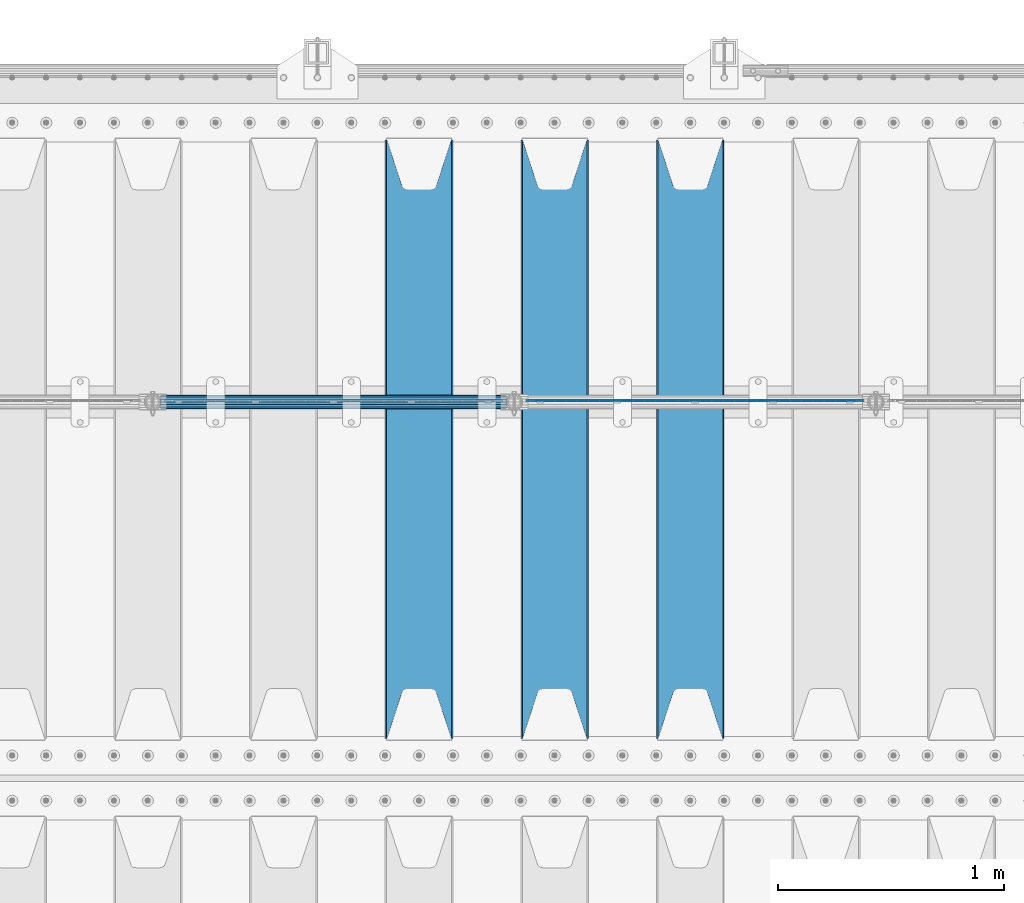
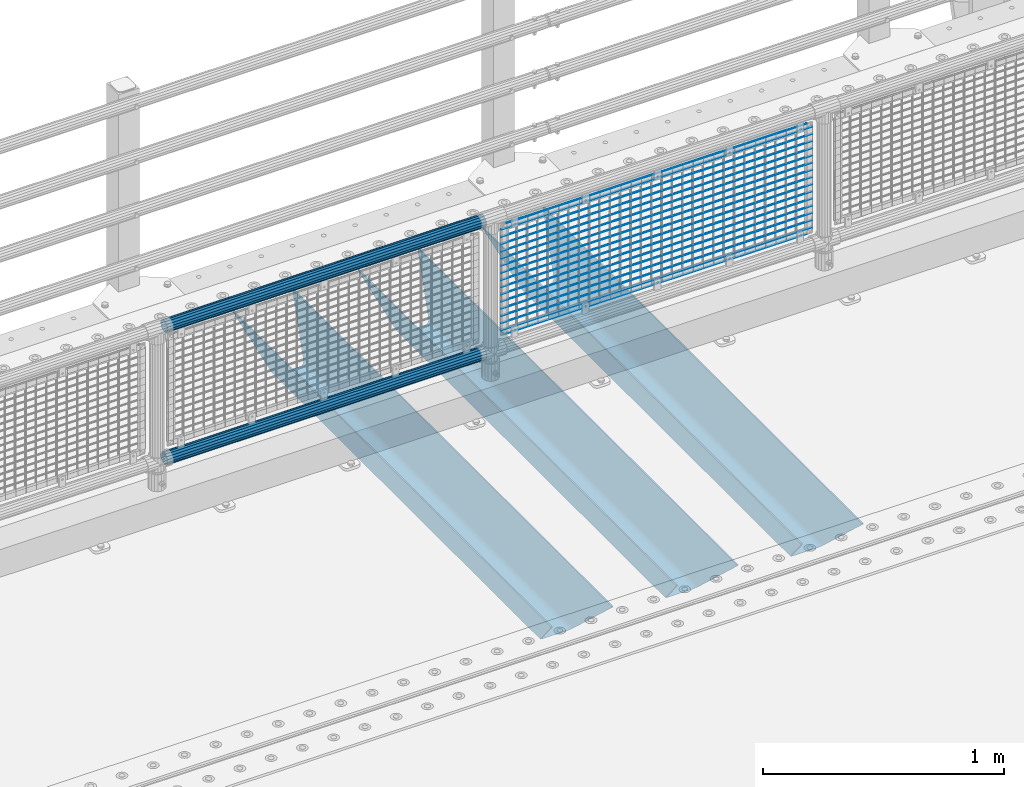
# One storey, part 103 of 208: 22 beams.
"""IFC2X3 building model written with IfcOpenShell, lengths in millimetres."""

from ifc_helpers import new_model, si_unit, frame, origin_with_axes, place, context, subcontext, project, spatial, faceted_brep, material, type_object, element, save


model = new_model("IFC2X3")

# Units and contexts
model_context = context("Model", 3, precision=1e-05, world=origin_with_axes())
body_context = subcontext(model_context, "Body", "Model", "MODEL_VIEW")
ifc_project = project(units=[si_unit("LENGTHUNIT", "METRE", prefix="MILLI"), si_unit("AREAUNIT", "SQUARE_METRE"), si_unit("VOLUMEUNIT", "CUBIC_METRE"), si_unit("MASSUNIT", "GRAM", prefix="KILO"), si_unit("TIMEUNIT", "SECOND"), si_unit("PLANEANGLEUNIT", "RADIAN"), si_unit("SOLIDANGLEUNIT", "STERADIAN"), si_unit("THERMODYNAMICTEMPERATUREUNIT", "DEGREE_CELSIUS"), si_unit("LUMINOUSINTENSITYUNIT", "LUMEN")], contexts=[model_context])

# Site, building, storey
site_placement = place(None, origin_with_axes())
site = spatial("IfcSite", under=ifc_project, at=site_placement, CompositionType="ELEMENT")
building_placement = place(site_placement, origin_with_axes())
building = spatial("IfcBuilding", under=site, at=building_placement, Name="Standard", CompositionType="ELEMENT")
storey_placement = place(building_placement, origin_with_axes())
storey = spatial("IfcBuildingStorey", under=building, at=storey_placement, Name="Undefined", CompositionType="ELEMENT", Elevation=0.0)

# Beams
ifc_material_1 = material(Name="STEEL/S355N")
beam_type_1 = type_object("IfcBeamType", PredefinedType="NOTDEFINED")
beam_1_placement = place(storey_placement, frame((-33050.0, 3175.0, -115.0), z_axis=(0.0, 0.0, 1.0), x_axis=(0.0, 1.0, 0.0)))
element("IfcBeam", 1, at=beam_1_placement, inside=storey, type_object=beam_type_1, material=ifc_material_1, context=body_context, shape_type="Brep", body=[
    faceted_brep([(0.0, 150.0, 115.0), (0.0, 143.689999999999, 115.0), (2650.00000000297, 143.689999999999, 115.0), (2650.00000000297, 150.0, 115.0), (2650.00000000297, 142.059565218402, 110.0000000031), (2650.00000000297, 148.369565218403, 110.0000000031), (2441.90079219208, -80.1103600731112, -98.0992078077845), (2437.7588105432, -77.5672621345584, -102.241189456673), (2434.06523489746, -74.4080125315522, -105.934765102404), (2430.91086095089, -70.710272125576, -109.089139048974), (2428.37322971128, -66.5649389910068, -111.626770288588), (2426.51472138055, -62.0739139532889, -113.485278619323), (2425.38102192091, -57.3475956567672, -114.618978078955), (2424.99999999987, -52.5021667386536, -115.0), (2424.99999999987, 52.5021667386536, -115.0), (2425.38102192091, 57.3475956567672, -114.618978078955), (2426.51472138055, 62.0739139532889, -113.485278619323), (2428.37322971128, 66.5649389910068, -111.626770288588), (2430.91086095089, 70.710272125576, -109.089139048974), (2434.06523489746, 74.4080125315522, -105.934765102404), (2437.7588105432, 77.5672621345584, -102.241189456673), (2441.90079219208, 80.1103600731112, -98.0992078077846), (2446.38936140511, 81.9747917625791, -93.6106385947584), (2448.24948500409, 76.2713538057251, -91.7505149957729), (2444.62967112262, 74.76777986261, -95.3703288772456), (2441.28936334126, 72.7168944282894, -98.710636658607), (2438.31067330438, 70.1691124903846, -101.689326695487), (2435.76682334747, 67.1870637758839, -104.233176652398), (2433.72034654133, 63.8440531834895, -106.279653458539), (2432.22154950041, 60.222258798236, -107.778450499454), (2431.30727574265, 56.4107117849089, -108.692724257221), (2430.99999999987, 52.5031078186876, -109.0), (2430.99999999987, -52.5031078186876, -109.0), (2431.30727574265, -56.4107117849089, -108.692724257221), (2432.22154950041, -60.222258798236, -107.778450499454), (2433.72034654133, -63.8440531834895, -106.279653458539), (2435.76682334747, -67.1870637758839, -104.233176652398), (2438.31067330438, -70.1691124903846, -101.689326695487), (2441.28936334126, -72.7168944282894, -98.7106366586071), (2444.62967112262, -74.76777986261, -95.3703288772457), (2448.24948500409, -76.2713538057251, -91.7505149957729), (2650.00000000297, -142.059565218402, 110.0000000031), (2650.00000000297, -148.369565218403, 110.0000000031), (2446.38936140511, -81.9747917625791, -93.6106385947584), (2650.00000000297, -143.689999999999, 115.0), (2650.00000000297, -150.0, 115.0), (0.0, -143.689999999999, 115.0), (0.0, -150.0, 115.0), (0.0, -148.369565218261, 110.000000002663), (203.610638597421, -81.9747917625791, -93.6106385947584), (208.099207810448, -80.1103600731112, -98.0992078077845), (212.241189459336, -77.5672621345584, -102.241189456673), (215.934765105067, -74.4080125315522, -105.934765102404), (219.089139051637, -70.710272125576, -109.089139048974), (221.626770291251, -66.5649389910068, -111.626770288588), (223.485278621986, -62.0739139532889, -113.485278619323), (224.618978081618, -57.3475956567672, -114.618978078955), (225.000000002663, -52.5021667386536, -115.0), (225.000000002663, 52.5021667386536, -115.0), (224.618978081618, 57.3475956567672, -114.618978078955), (223.485278621986, 62.0739139532889, -113.485278619323), (221.626770291251, 66.5649389910068, -111.626770288588), (219.089139051637, 70.710272125576, -109.089139048974), (215.934765105067, 74.4080125315522, -105.934765102404), (212.241189459336, 77.5672621345584, -102.241189456673), (208.099207810448, 80.1103600731112, -98.0992078077846), (203.610638597421, 81.9747917625791, -93.6106385947584), (0.0, 148.369565218261, 110.000000002663), (0.0, 142.05956521826, 110.000000002663), (201.750514998436, 76.2713538057251, -91.7505149957729), (205.370328879908, 74.76777986261, -95.3703288772456), (208.71063666127, 72.7168944282894, -98.710636658607), (211.68932669815, 70.1691124903846, -101.689326695487), (214.233176655061, 67.1870637758839, -104.233176652398), (216.279653461202, 63.8440531834895, -106.279653458539), (217.778450502116, 60.222258798236, -107.778450499454), (218.692724259884, 56.4107117849089, -108.692724257221), (219.000000002663, 52.5031078186876, -109.0), (219.000000002663, -52.5031078186876, -109.0), (218.692724259884, -56.4107117849089, -108.692724257221), (217.778450502116, -60.222258798236, -107.778450499454), (216.279653461202, -63.8440531834895, -106.279653458539), (214.233176655061, -67.1870637758839, -104.233176652398), (211.68932669815, -70.1691124903846, -101.689326695487), (208.71063666127, -72.7168944282894, -98.7106366586071), (205.370328879908, -74.76777986261, -95.3703288772457), (201.750514998436, -76.2713538057251, -91.7505149957729), (0.0, -142.05956521826, 110.000000002663)], [[[0, 1, 2, 3]], [[3, 2, 4, 5]], [[6, 7, 8, 9, 10, 11, 12, 13, 14, 15, 16, 17, 18, 19, 20, 21, 22, 5, 4, 23, 24, 25, 26, 27, 28, 29, 30, 31, 32, 33, 34, 35, 36, 37, 38, 39, 40, 41, 42, 43]], [[44, 45, 42, 41]], [[46, 47, 45, 44]], [[43, 42, 45, 47, 48, 49]], [[6, 43, 49, 50]], [[7, 6, 50, 51]], [[8, 7, 51, 52]], [[9, 8, 52, 53]], [[10, 9, 53, 54]], [[11, 10, 54, 55]], [[12, 11, 55, 56]], [[13, 12, 56, 57]], [[14, 13, 57, 58]], [[15, 14, 58, 59]], [[16, 15, 59, 60]], [[17, 16, 60, 61]], [[18, 17, 61, 62]], [[19, 18, 62, 63]], [[20, 19, 63, 64]], [[21, 20, 64, 65]], [[22, 21, 65, 66]], [[0, 3, 5, 22, 66, 67]], [[1, 0, 67, 68]], [[23, 4, 2, 1, 68, 69]], [[24, 23, 69, 70]], [[25, 24, 70, 71]], [[26, 25, 71, 72]], [[27, 26, 72, 73]], [[28, 27, 73, 74]], [[29, 28, 74, 75]], [[30, 29, 75, 76]], [[31, 30, 76, 77]], [[32, 31, 77, 78]], [[33, 32, 78, 79]], [[34, 33, 79, 80]], [[35, 34, 80, 81]], [[36, 35, 81, 82]], [[37, 36, 82, 83]], [[38, 37, 83, 84]], [[39, 38, 84, 85]], [[40, 39, 85, 86]], [[46, 44, 41, 40, 86, 87]], [[47, 46, 87, 48]], [[86, 85, 84, 83, 82, 81, 80, 79, 78, 77, 76, 75, 74, 73, 72, 71, 70, 69, 68, 67, 66, 65, 64, 63, 62, 61, 60, 59, 58, 57, 56, 55, 54, 53, 52, 51, 50, 49, 48, 87]]]),
])
beam_2_placement = place(storey_placement, frame((-33650.0, 3175.0, -115.0), z_axis=(0.0, 0.0, 1.0), x_axis=(0.0, 1.0, 0.0)))
element("IfcBeam", 2, at=beam_2_placement, inside=storey, type_object=beam_type_1, material=ifc_material_1, context=body_context, shape_type="Brep", body=[
    faceted_brep([(0.0, 150.0, 115.0), (0.0, 143.689999999999, 115.0), (2650.00000000297, 143.689999999999, 115.0), (2650.00000000297, 150.0, 115.0), (2650.00000000297, 142.059565218402, 110.0000000031), (2650.00000000297, 148.369565218403, 110.0000000031), (2441.90079219208, -80.1103600731112, -98.0992078077845), (2437.7588105432, -77.5672621345584, -102.241189456673), (2434.06523489746, -74.4080125315522, -105.934765102404), (2430.91086095089, -70.710272125576, -109.089139048974), (2428.37322971128, -66.5649389910068, -111.626770288588), (2426.51472138055, -62.0739139532889, -113.485278619323), (2425.38102192091, -57.3475956567672, -114.618978078955), (2424.99999999987, -52.5021667386536, -115.0), (2424.99999999987, 52.5021667386536, -115.0), (2425.38102192091, 57.3475956567672, -114.618978078955), (2426.51472138055, 62.0739139532889, -113.485278619323), (2428.37322971128, 66.5649389910068, -111.626770288588), (2430.91086095089, 70.710272125576, -109.089139048974), (2434.06523489746, 74.4080125315522, -105.934765102404), (2437.7588105432, 77.5672621345584, -102.241189456673), (2441.90079219208, 80.1103600731112, -98.0992078077846), (2446.38936140511, 81.9747917625791, -93.6106385947584), (2448.24948500409, 76.2713538057251, -91.7505149957729), (2444.62967112262, 74.76777986261, -95.3703288772456), (2441.28936334126, 72.7168944282894, -98.710636658607), (2438.31067330438, 70.1691124903846, -101.689326695487), (2435.76682334747, 67.1870637758839, -104.233176652398), (2433.72034654133, 63.8440531834895, -106.279653458539), (2432.22154950041, 60.222258798236, -107.778450499454), (2431.30727574265, 56.4107117849089, -108.692724257221), (2430.99999999987, 52.5031078186876, -109.0), (2430.99999999987, -52.5031078186876, -109.0), (2431.30727574265, -56.4107117849089, -108.692724257221), (2432.22154950041, -60.222258798236, -107.778450499454), (2433.72034654133, -63.8440531834895, -106.279653458539), (2435.76682334747, -67.1870637758839, -104.233176652398), (2438.31067330438, -70.1691124903846, -101.689326695487), (2441.28936334126, -72.7168944282894, -98.7106366586071), (2444.62967112262, -74.76777986261, -95.3703288772457), (2448.24948500409, -76.2713538057251, -91.7505149957729), (2650.00000000297, -142.059565218402, 110.0000000031), (2650.00000000297, -148.369565218403, 110.0000000031), (2446.38936140511, -81.9747917625791, -93.6106385947584), (2650.00000000297, -143.689999999999, 115.0), (2650.00000000297, -150.0, 115.0), (0.0, -143.689999999999, 115.0), (0.0, -150.0, 115.0), (0.0, -148.369565218261, 110.000000002663), (203.610638597421, -81.9747917625791, -93.6106385947584), (208.099207810448, -80.1103600731112, -98.0992078077845), (212.241189459336, -77.5672621345584, -102.241189456673), (215.934765105067, -74.4080125315522, -105.934765102404), (219.089139051637, -70.710272125576, -109.089139048974), (221.626770291251, -66.5649389910068, -111.626770288588), (223.485278621986, -62.0739139532889, -113.485278619323), (224.618978081618, -57.3475956567672, -114.618978078955), (225.000000002663, -52.5021667386536, -115.0), (225.000000002663, 52.5021667386536, -115.0), (224.618978081618, 57.3475956567672, -114.618978078955), (223.485278621986, 62.0739139532889, -113.485278619323), (221.626770291251, 66.5649389910068, -111.626770288588), (219.089139051637, 70.710272125576, -109.089139048974), (215.934765105067, 74.4080125315522, -105.934765102404), (212.241189459336, 77.5672621345584, -102.241189456673), (208.099207810448, 80.1103600731112, -98.0992078077846), (203.610638597421, 81.9747917625791, -93.6106385947584), (0.0, 148.369565218261, 110.000000002663), (0.0, 142.05956521826, 110.000000002663), (201.750514998436, 76.2713538057251, -91.7505149957729), (205.370328879908, 74.76777986261, -95.3703288772456), (208.71063666127, 72.7168944282894, -98.710636658607), (211.68932669815, 70.1691124903846, -101.689326695487), (214.233176655061, 67.1870637758839, -104.233176652398), (216.279653461202, 63.8440531834895, -106.279653458539), (217.778450502116, 60.222258798236, -107.778450499454), (218.692724259884, 56.4107117849089, -108.692724257221), (219.000000002663, 52.5031078186876, -109.0), (219.000000002663, -52.5031078186876, -109.0), (218.692724259884, -56.4107117849089, -108.692724257221), (217.778450502116, -60.222258798236, -107.778450499454), (216.279653461202, -63.8440531834895, -106.279653458539), (214.233176655061, -67.1870637758839, -104.233176652398), (211.68932669815, -70.1691124903846, -101.689326695487), (208.71063666127, -72.7168944282894, -98.7106366586071), (205.370328879908, -74.76777986261, -95.3703288772457), (201.750514998436, -76.2713538057251, -91.7505149957729), (0.0, -142.05956521826, 110.000000002663)], [[[0, 1, 2, 3]], [[3, 2, 4, 5]], [[6, 7, 8, 9, 10, 11, 12, 13, 14, 15, 16, 17, 18, 19, 20, 21, 22, 5, 4, 23, 24, 25, 26, 27, 28, 29, 30, 31, 32, 33, 34, 35, 36, 37, 38, 39, 40, 41, 42, 43]], [[44, 45, 42, 41]], [[46, 47, 45, 44]], [[43, 42, 45, 47, 48, 49]], [[6, 43, 49, 50]], [[7, 6, 50, 51]], [[8, 7, 51, 52]], [[9, 8, 52, 53]], [[10, 9, 53, 54]], [[11, 10, 54, 55]], [[12, 11, 55, 56]], [[13, 12, 56, 57]], [[14, 13, 57, 58]], [[15, 14, 58, 59]], [[16, 15, 59, 60]], [[17, 16, 60, 61]], [[18, 17, 61, 62]], [[19, 18, 62, 63]], [[20, 19, 63, 64]], [[21, 20, 64, 65]], [[22, 21, 65, 66]], [[0, 3, 5, 22, 66, 67]], [[1, 0, 67, 68]], [[23, 4, 2, 1, 68, 69]], [[24, 23, 69, 70]], [[25, 24, 70, 71]], [[26, 25, 71, 72]], [[27, 26, 72, 73]], [[28, 27, 73, 74]], [[29, 28, 74, 75]], [[30, 29, 75, 76]], [[31, 30, 76, 77]], [[32, 31, 77, 78]], [[33, 32, 78, 79]], [[34, 33, 79, 80]], [[35, 34, 80, 81]], [[36, 35, 81, 82]], [[37, 36, 82, 83]], [[38, 37, 83, 84]], [[39, 38, 84, 85]], [[40, 39, 85, 86]], [[46, 44, 41, 40, 86, 87]], [[47, 46, 87, 48]], [[86, 85, 84, 83, 82, 81, 80, 79, 78, 77, 76, 75, 74, 73, 72, 71, 70, 69, 68, 67, 66, 65, 64, 63, 62, 61, 60, 59, 58, 57, 56, 55, 54, 53, 52, 51, 50, 49, 48, 87]]]),
])
beam_3_placement = place(storey_placement, frame((-34250.0, 3175.0, -115.0), z_axis=(0.0, 0.0, 1.0), x_axis=(0.0, 1.0, 0.0)))
element("IfcBeam", 3, at=beam_3_placement, inside=storey, type_object=beam_type_1, material=ifc_material_1, context=body_context, shape_type="Brep", body=[
    faceted_brep([(0.0, 150.0, 115.0), (0.0, 143.689999999999, 115.0), (2650.00000000297, 143.689999999999, 115.0), (2650.00000000297, 150.0, 115.0), (2650.00000000297, 142.059565218402, 110.0000000031), (2650.00000000297, 148.369565218403, 110.0000000031), (2441.90079219208, -80.1103600731112, -98.0992078077845), (2437.7588105432, -77.5672621345584, -102.241189456673), (2434.06523489746, -74.4080125315522, -105.934765102404), (2430.91086095089, -70.710272125576, -109.089139048974), (2428.37322971128, -66.5649389910068, -111.626770288588), (2426.51472138055, -62.0739139532889, -113.485278619323), (2425.38102192091, -57.3475956567672, -114.618978078955), (2424.99999999987, -52.5021667386536, -115.0), (2424.99999999987, 52.5021667386536, -115.0), (2425.38102192091, 57.3475956567672, -114.618978078955), (2426.51472138055, 62.0739139532889, -113.485278619323), (2428.37322971128, 66.5649389910068, -111.626770288588), (2430.91086095089, 70.710272125576, -109.089139048974), (2434.06523489746, 74.4080125315522, -105.934765102404), (2437.7588105432, 77.5672621345584, -102.241189456673), (2441.90079219208, 80.1103600731112, -98.0992078077846), (2446.38936140511, 81.9747917625791, -93.6106385947584), (2448.24948500409, 76.2713538057251, -91.7505149957729), (2444.62967112262, 74.76777986261, -95.3703288772456), (2441.28936334126, 72.7168944282894, -98.710636658607), (2438.31067330438, 70.1691124903846, -101.689326695487), (2435.76682334747, 67.1870637758839, -104.233176652398), (2433.72034654133, 63.8440531834895, -106.279653458539), (2432.22154950041, 60.222258798236, -107.778450499454), (2431.30727574265, 56.4107117849089, -108.692724257221), (2430.99999999987, 52.5031078186876, -109.0), (2430.99999999987, -52.5031078186876, -109.0), (2431.30727574265, -56.4107117849089, -108.692724257221), (2432.22154950041, -60.222258798236, -107.778450499454), (2433.72034654133, -63.8440531834895, -106.279653458539), (2435.76682334747, -67.1870637758839, -104.233176652398), (2438.31067330438, -70.1691124903846, -101.689326695487), (2441.28936334126, -72.7168944282894, -98.7106366586071), (2444.62967112262, -74.76777986261, -95.3703288772457), (2448.24948500409, -76.2713538057251, -91.7505149957729), (2650.00000000297, -142.059565218402, 110.0000000031), (2650.00000000297, -148.369565218403, 110.0000000031), (2446.38936140511, -81.9747917625791, -93.6106385947584), (2650.00000000297, -143.689999999999, 115.0), (2650.00000000297, -150.0, 115.0), (0.0, -143.689999999999, 115.0), (0.0, -150.0, 115.0), (0.0, -148.369565218261, 110.000000002663), (203.610638597421, -81.9747917625791, -93.6106385947584), (208.099207810448, -80.1103600731112, -98.0992078077845), (212.241189459336, -77.5672621345584, -102.241189456673), (215.934765105067, -74.4080125315522, -105.934765102404), (219.089139051637, -70.710272125576, -109.089139048974), (221.626770291251, -66.5649389910068, -111.626770288588), (223.485278621986, -62.0739139532889, -113.485278619323), (224.618978081618, -57.3475956567672, -114.618978078955), (225.000000002663, -52.5021667386536, -115.0), (225.000000002663, 52.5021667386536, -115.0), (224.618978081618, 57.3475956567672, -114.618978078955), (223.485278621986, 62.0739139532889, -113.485278619323), (221.626770291251, 66.5649389910068, -111.626770288588), (219.089139051637, 70.710272125576, -109.089139048974), (215.934765105067, 74.4080125315522, -105.934765102404), (212.241189459336, 77.5672621345584, -102.241189456673), (208.099207810448, 80.1103600731112, -98.0992078077846), (203.610638597421, 81.9747917625791, -93.6106385947584), (0.0, 148.369565218261, 110.000000002663), (0.0, 142.05956521826, 110.000000002663), (201.750514998436, 76.2713538057251, -91.7505149957729), (205.370328879908, 74.76777986261, -95.3703288772456), (208.71063666127, 72.7168944282894, -98.710636658607), (211.68932669815, 70.1691124903846, -101.689326695487), (214.233176655061, 67.1870637758839, -104.233176652398), (216.279653461202, 63.8440531834895, -106.279653458539), (217.778450502116, 60.222258798236, -107.778450499454), (218.692724259884, 56.4107117849089, -108.692724257221), (219.000000002663, 52.5031078186876, -109.0), (219.000000002663, -52.5031078186876, -109.0), (218.692724259884, -56.4107117849089, -108.692724257221), (217.778450502116, -60.222258798236, -107.778450499454), (216.279653461202, -63.8440531834895, -106.279653458539), (214.233176655061, -67.1870637758839, -104.233176652398), (211.68932669815, -70.1691124903846, -101.689326695487), (208.71063666127, -72.7168944282894, -98.7106366586071), (205.370328879908, -74.76777986261, -95.3703288772457), (201.750514998436, -76.2713538057251, -91.7505149957729), (0.0, -142.05956521826, 110.000000002663)], [[[0, 1, 2, 3]], [[3, 2, 4, 5]], [[6, 7, 8, 9, 10, 11, 12, 13, 14, 15, 16, 17, 18, 19, 20, 21, 22, 5, 4, 23, 24, 25, 26, 27, 28, 29, 30, 31, 32, 33, 34, 35, 36, 37, 38, 39, 40, 41, 42, 43]], [[44, 45, 42, 41]], [[46, 47, 45, 44]], [[43, 42, 45, 47, 48, 49]], [[6, 43, 49, 50]], [[7, 6, 50, 51]], [[8, 7, 51, 52]], [[9, 8, 52, 53]], [[10, 9, 53, 54]], [[11, 10, 54, 55]], [[12, 11, 55, 56]], [[13, 12, 56, 57]], [[14, 13, 57, 58]], [[15, 14, 58, 59]], [[16, 15, 59, 60]], [[17, 16, 60, 61]], [[18, 17, 61, 62]], [[19, 18, 62, 63]], [[20, 19, 63, 64]], [[21, 20, 64, 65]], [[22, 21, 65, 66]], [[0, 3, 5, 22, 66, 67]], [[1, 0, 67, 68]], [[23, 4, 2, 1, 68, 69]], [[24, 23, 69, 70]], [[25, 24, 70, 71]], [[26, 25, 71, 72]], [[27, 26, 72, 73]], [[28, 27, 73, 74]], [[29, 28, 74, 75]], [[30, 29, 75, 76]], [[31, 30, 76, 77]], [[32, 31, 77, 78]], [[33, 32, 78, 79]], [[34, 33, 79, 80]], [[35, 34, 80, 81]], [[36, 35, 81, 82]], [[37, 36, 82, 83]], [[38, 37, 83, 84]], [[39, 38, 84, 85]], [[40, 39, 85, 86]], [[46, 44, 41, 40, 86, 87]], [[47, 46, 87, 48]], [[86, 85, 84, 83, 82, 81, 80, 79, 78, 77, 76, 75, 74, 73, 72, 71, 70, 69, 68, 67, 66, 65, 64, 63, 62, 61, 60, 59, 58, 57, 56, 55, 54, 53, 52, 51, 50, 49, 48, 87]]]),
])
ifc_material_2 = material(Name="Misc_Undefined")
beam_type_2 = type_object("IfcBeamType", Name="D3", PredefinedType="NOTDEFINED")
for number, where, z_axis, x_axis in (
    (4, (-33774.0, 4670.5, 851.597000000003), (0.0, 0.0, 1.0), (1.0, 0.0, 0.0)),
    (5, (-33774.0, 4670.5, 669.452000000003), (0.0, 0.0, 1.0), (1.0, 0.0, 0.0)),
    (6, (-33774.0, 4670.5, 523.736000000003), (0.0, 0.0, 1.0), (1.0, 0.0, 0.0)),
    (7, (-33774.0, 4670.5, 487.307000000003), (0.0, 0.0, 1.0), (1.0, 0.0, 0.0)),
    (8, (-33774.0, 4670.5, 705.881000000003), (0.0, 0.0, 1.0), (1.0, 0.0, 0.0)),
    (9, (-33774.0, 4670.5, 596.594000000003), (0.0, 0.0, 1.0), (1.0, 0.0, 0.0)),
    (10, (-33774.0, 4670.5, 450.878000000003), (0.0, 0.0, 1.0), (1.0, 0.0, 0.0)),
    (11, (-33774.0, 4670.5, 815.168000000003), (0.0, 0.0, 1.0), (1.0, 0.0, 0.0)),
    (12, (-33774.0, 4670.5, 888.026000000003), (0.0, 0.0, 1.0), (1.0, 0.0, 0.0)),
    (13, (-33774.0, 4670.5, 778.739000000003), (0.0, 0.0, 1.0), (1.0, 0.0, 0.0)),
    (14, (-33774.0, 4670.5, 742.310000000003), (0.0, 0.0, 1.0), (1.0, 0.0, 0.0)),
    (15, (-33774.0, 4670.5, 633.023000000003), (0.0, 0.0, 1.0), (1.0, 0.0, 0.0)),
    (16, (-33774.0, 4670.5, 560.165000000003), (0.0, 0.0, 1.0), (1.0, 0.0, 0.0)),
    (17, (-33774.0, 4670.5, 414.449000000003), (0.0, 0.0, 1.0), (1.0, 0.0, 0.0)),
):
    element("IfcBeam", number, at=place(storey_placement, frame(where, z_axis=z_axis, x_axis=x_axis)), inside=storey, type_object=beam_type_2, material=ifc_material_2, ObjectType="D3", context=body_context, shape_type="Brep", body=[
        faceted_brep([(0.0, -1.49999999999909, 3.63797880709171e-12), (-7.27595761418343e-12, -0.749999999999091, -1.29903810567669), (1490.0, -0.75, -1.29903810567669), (1490.0, -1.5, 0.0), (-3.63797880709171e-12, 0.750000000000909, -1.29903810567669), (1490.0, 0.75, -1.29903810567669), (0.0, 1.50000000000182, 3.63797880709171e-12), (1490.0, 1.5, 0.0), (-3.63797880709171e-12, 0.750000000000909, 1.29903810567669), (1490.0, 0.75, 1.29903810567669), (-7.27595761418343e-12, -0.749999999999091, 1.29903810567669), (1490.0, -0.75, 1.29903810567669)], [[[0, 1, 2, 3]], [[1, 4, 5, 2]], [[4, 6, 7, 5]], [[6, 8, 9, 7]], [[8, 10, 11, 9]], [[10, 0, 3, 11]], [[5, 7, 9, 11, 3, 2]], [[10, 8, 6, 4, 1, 0]]]),
    ])
beam_4_placement = place(storey_placement, frame((-33749.0, 4670.5, 353.020000000003), z_axis=(0.0, 0.0, 1.0), x_axis=(1.0, 0.0, 0.0)))
element("IfcBeam", 18, at=beam_4_placement, inside=storey, type_object=beam_type_2, material=ifc_material_2, ObjectType="D3", context=body_context, shape_type="Brep", body=[
    faceted_brep([(0.0, -1.49999999999909, 3.63797880709171e-12), (-7.27595761418343e-12, -0.749999999999091, -1.29903810567669), (1440.0, -0.75, -1.29903810567669), (1440.0, -1.5, 0.0), (-3.63797880709171e-12, 0.750000000000909, -1.29903810567669), (1440.0, 0.75, -1.29903810567663), (0.0, 1.50000000000182, 3.63797880709171e-12), (1440.0, 1.5, 0.0), (-3.63797880709171e-12, 0.750000000000909, 1.29903810567669), (1440.0, 0.75, 1.29903810567669), (-7.27595761418343e-12, -0.749999999999091, 1.29903810567669), (1440.0, -0.75, 1.29903810567669)], [[[0, 1, 2, 3]], [[1, 4, 5, 2]], [[4, 6, 7, 5]], [[6, 8, 9, 7]], [[8, 10, 11, 9]], [[10, 0, 3, 11]], [[5, 7, 9, 11, 3, 2]], [[10, 8, 6, 4, 1, 0]]]),
])
beam_5_placement = place(storey_placement, frame((-33774.0, 4670.5, 378.020000000003), z_axis=(0.0, 0.0, 1.0), x_axis=(1.0, 0.0, 0.0)))
element("IfcBeam", 19, at=beam_5_placement, inside=storey, type_object=beam_type_2, material=ifc_material_2, ObjectType="D3", context=body_context, shape_type="Brep", body=[
    faceted_brep([(0.0, -1.49999999999909, 3.63797880709171e-12), (-7.27595761418343e-12, -0.749999999999091, -1.29903810567669), (1490.0, -0.75, -1.29903810567669), (1490.0, -1.5, 0.0), (-3.63797880709171e-12, 0.750000000000909, -1.29903810567669), (1490.0, 0.75, -1.29903810567669), (0.0, 1.50000000000182, 3.63797880709171e-12), (1490.0, 1.5, 0.0), (-3.63797880709171e-12, 0.750000000000909, 1.29903810567669), (1490.0, 0.75, 1.29903810567669), (-7.27595761418343e-12, -0.749999999999091, 1.29903810567669), (1490.0, -0.75, 1.29903810567669)], [[[0, 1, 2, 3]], [[1, 4, 5, 2]], [[4, 6, 7, 5]], [[6, 8, 9, 7]], [[8, 10, 11, 9]], [[10, 0, 3, 11]], [[5, 7, 9, 11, 3, 2]], [[10, 8, 6, 4, 1, 0]]]),
])
beam_6_placement = place(storey_placement, frame((-33749.0, 4670.5, 913.020000000003), z_axis=(0.0, 0.0, 1.0), x_axis=(1.0, 0.0, 0.0)))
element("IfcBeam", 20, at=beam_6_placement, inside=storey, type_object=beam_type_2, material=ifc_material_2, ObjectType="D3", context=body_context, shape_type="Brep", body=[
    faceted_brep([(0.0, -1.49999999999909, 3.63797880709171e-12), (-7.27595761418343e-12, -0.749999999999091, -1.29903810567669), (1440.0, -0.75, -1.29903810567669), (1440.0, -1.5, 0.0), (-3.63797880709171e-12, 0.750000000000909, -1.29903810567669), (1440.0, 0.75, -1.29903810567663), (0.0, 1.50000000000182, 3.63797880709171e-12), (1440.0, 1.5, 0.0), (-3.63797880709171e-12, 0.750000000000909, 1.29903810567669), (1440.0, 0.75, 1.29903810567669), (-7.27595761418343e-12, -0.749999999999091, 1.29903810567669), (1440.0, -0.75, 1.29903810567669)], [[[0, 1, 2, 3]], [[1, 4, 5, 2]], [[4, 6, 7, 5]], [[6, 8, 9, 7]], [[8, 10, 11, 9]], [[10, 0, 3, 11]], [[5, 7, 9, 11, 3, 2]], [[10, 8, 6, 4, 1, 0]]]),
])
ifc_material_3 = material()
beam_type_3 = type_object("IfcBeamType", PredefinedType="NOTDEFINED")
beam_7_placement = place(storey_placement, frame((-35394.15, 4664.5, 298.170000000003), z_axis=(0.0, 0.0, 1.0), x_axis=(1.0, 0.0, 0.0)))
element("IfcBeam", 21, at=beam_7_placement, inside=storey, type_object=beam_type_3, material=ifc_material_3, context=body_context, shape_type="Brep", body=[
    faceted_brep([(0.0, -25.3500000000004, 0.0), (0.0, -23.4203461491616, 9.70102501045403), (1530.0, -23.4203461491616, 9.70102501045506), (1530.0, -25.3500000000004, 0.0), (0.0, -17.9251569030794, 17.9251569030785), (1530.0, -17.9251569030794, 17.925156903079), (0.0, -9.70102501045494, 23.4203461491597), (1530.0, -9.70102501045494, 23.4203461491611), (0.0, 0.0, 25.3499999999985), (1530.0, 0.0, 25.35), (0.0, 9.70102501045494, 23.4203461491597), (1530.0, 9.70102501045494, 23.4203461491611), (0.0, 17.9251569030794, 17.9251569030785), (1530.0, 17.9251569030794, 17.925156903079), (0.0, 23.4203461491616, 9.70102501045403), (1530.0, 23.4203461491616, 9.701025010455), (0.0, 25.3500000000004, 0.0), (1530.0, 25.3500000000004, 0.0), (0.0, 23.4203461491616, -9.70102501045403), (1530.0, 23.4203461491616, -9.70102501045506), (0.0, 17.9251569030794, -17.9251569030785), (1530.0, 17.9251569030794, -17.925156903079), (0.0, 9.70102501045494, -23.4203461491597), (1530.0, 9.70102501045494, -23.4203461491611), (0.0, 0.0, -25.3499999999985), (1530.0, 0.0, -25.35), (0.0, -9.70102501045494, -23.4203461491597), (1530.0, -9.70102501045494, -23.4203461491611), (0.0, -17.9251569030794, -17.9251569030785), (1530.0, -17.9251569030794, -17.925156903079), (0.0, -23.4203461491616, -9.70102501045403), (1530.0, -23.4203461491616, -9.701025010455), (0.0, -30.1499999999996, 0.0), (0.0, -27.8549679052148, -11.5379054858058), (1530.0, -27.8549679052148, -11.5379054858075), (1530.0, -30.1499999999996, 0.0), (0.0, -21.3192694527743, -21.3192694527752), (1530.0, -21.3192694527743, -21.3192694527744), (0.0, -11.5379054858076, -27.8549679052157), (1530.0, -11.5379054858076, -27.8549679052153), (0.0, 0.0, -30.1500000000015), (1530.0, 0.0, -30.15), (0.0, 11.5379054858076, -27.8549679052157), (1530.0, 11.5379054858076, -27.8549679052153), (0.0, 21.3192694527743, -21.3192694527752), (1530.0, 21.3192694527743, -21.3192694527744), (0.0, 27.8549679052157, -11.5379054858058), (1530.0, 27.8549679052157, -11.5379054858075), (0.0, 30.1499999999996, 0.0), (1530.0, 30.1499999999996, 0.0), (0.0, 27.8549679052157, 11.5379054858058), (1530.0, 27.8549679052157, 11.5379054858075), (0.0, 21.3192694527743, 21.3192694527752), (1530.0, 21.3192694527743, 21.3192694527744), (0.0, 11.5379054858076, 27.8549679052157), (1530.0, 11.5379054858076, 27.8549679052153), (0.0, 0.0, 30.1500000000015), (1530.0, 0.0, 30.15), (0.0, -11.5379054858076, 27.8549679052157), (1530.0, -11.5379054858076, 27.8549679052153), (0.0, -21.3192694527743, 21.3192694527752), (1530.0, -21.3192694527743, 21.3192694527744), (0.0, -27.8549679052157, 11.5379054858058), (1530.0, -27.8549679052157, 11.5379054858075)], [[[0, 1, 2, 3]], [[1, 4, 5, 2]], [[4, 6, 7, 5]], [[6, 8, 9, 7]], [[8, 10, 11, 9]], [[10, 12, 13, 11]], [[12, 14, 15, 13]], [[14, 16, 17, 15]], [[16, 18, 19, 17]], [[18, 20, 21, 19]], [[20, 22, 23, 21]], [[22, 24, 25, 23]], [[24, 26, 27, 25]], [[26, 28, 29, 27]], [[28, 30, 31, 29]], [[30, 0, 3, 31]], [[32, 33, 34, 35]], [[33, 36, 37, 34]], [[36, 38, 39, 37]], [[38, 40, 41, 39]], [[40, 42, 43, 41]], [[42, 44, 45, 43]], [[44, 46, 47, 45]], [[46, 48, 49, 47]], [[48, 50, 51, 49]], [[50, 52, 53, 51]], [[52, 54, 55, 53]], [[54, 56, 57, 55]], [[56, 58, 59, 57]], [[58, 60, 61, 59]], [[60, 62, 63, 61]], [[62, 32, 35, 63]], [[37, 39, 41, 43, 45, 47, 49, 51, 53, 55, 57, 59, 61, 63, 35, 34], [5, 7, 9, 11, 13, 15, 17, 19, 21, 23, 25, 27, 29, 31, 3, 2]], [[62, 60, 58, 56, 54, 52, 50, 48, 46, 44, 42, 40, 38, 36, 33, 32], [30, 28, 26, 24, 22, 20, 18, 16, 14, 12, 10, 8, 6, 4, 1, 0]]]),
])
beam_8_placement = place(storey_placement, frame((-35394.15, 4664.5, 969.850000000002), z_axis=(0.0, 0.0, 1.0), x_axis=(1.0, 0.0, 0.0)))
element("IfcBeam", 22, at=beam_8_placement, inside=storey, type_object=beam_type_3, material=ifc_material_3, context=body_context, shape_type="Brep", body=[
    faceted_brep([(0.0, -25.3500000000004, 0.0), (0.0, -23.4203461491616, 9.70102501045403), (1530.0, -23.4203461491616, 9.70102501045506), (1530.0, -25.3500000000004, 0.0), (0.0, -17.9251569030794, 17.9251569030785), (1530.0, -17.9251569030794, 17.925156903079), (0.0, -9.70102501045494, 23.4203461491597), (1530.0, -9.70102501045494, 23.4203461491611), (0.0, 0.0, 25.3499999999985), (1530.0, 0.0, 25.35), (0.0, 9.70102501045494, 23.4203461491597), (1530.0, 9.70102501045494, 23.4203461491611), (0.0, 17.9251569030794, 17.9251569030785), (1530.0, 17.9251569030794, 17.925156903079), (0.0, 23.4203461491616, 9.70102501045403), (1530.0, 23.4203461491616, 9.701025010455), (0.0, 25.3500000000004, 0.0), (1530.0, 25.3500000000004, 0.0), (0.0, 23.4203461491616, -9.70102501045403), (1530.0, 23.4203461491616, -9.70102501045506), (0.0, 17.9251569030794, -17.9251569030785), (1530.0, 17.9251569030794, -17.925156903079), (0.0, 9.70102501045494, -23.4203461491597), (1530.0, 9.70102501045494, -23.4203461491611), (0.0, 0.0, -25.3499999999985), (1530.0, 0.0, -25.35), (0.0, -9.70102501045494, -23.4203461491597), (1530.0, -9.70102501045494, -23.4203461491611), (0.0, -17.9251569030794, -17.9251569030785), (1530.0, -17.9251569030794, -17.925156903079), (0.0, -23.4203461491616, -9.70102501045403), (1530.0, -23.4203461491616, -9.701025010455), (0.0, -30.1499999999996, 0.0), (0.0, -27.8549679052148, -11.5379054858058), (1530.0, -27.8549679052148, -11.5379054858075), (1530.0, -30.1499999999996, 0.0), (0.0, -21.3192694527743, -21.3192694527752), (1530.0, -21.3192694527743, -21.3192694527744), (0.0, -11.5379054858076, -27.8549679052157), (1530.0, -11.5379054858076, -27.8549679052153), (0.0, 0.0, -30.1500000000015), (1530.0, 0.0, -30.15), (0.0, 11.5379054858076, -27.8549679052157), (1530.0, 11.5379054858076, -27.8549679052153), (0.0, 21.3192694527743, -21.3192694527752), (1530.0, 21.3192694527743, -21.3192694527744), (0.0, 27.8549679052157, -11.5379054858058), (1530.0, 27.8549679052157, -11.5379054858075), (0.0, 30.1499999999996, 0.0), (1530.0, 30.1499999999996, 0.0), (0.0, 27.8549679052157, 11.5379054858058), (1530.0, 27.8549679052157, 11.5379054858075), (0.0, 21.3192694527743, 21.3192694527752), (1530.0, 21.3192694527743, 21.3192694527744), (0.0, 11.5379054858076, 27.8549679052157), (1530.0, 11.5379054858076, 27.8549679052153), (0.0, 0.0, 30.1500000000015), (1530.0, 0.0, 30.15), (0.0, -11.5379054858076, 27.8549679052157), (1530.0, -11.5379054858076, 27.8549679052153), (0.0, -21.3192694527743, 21.3192694527752), (1530.0, -21.3192694527743, 21.3192694527744), (0.0, -27.8549679052157, 11.5379054858058), (1530.0, -27.8549679052157, 11.5379054858075)], [[[0, 1, 2, 3]], [[1, 4, 5, 2]], [[4, 6, 7, 5]], [[6, 8, 9, 7]], [[8, 10, 11, 9]], [[10, 12, 13, 11]], [[12, 14, 15, 13]], [[14, 16, 17, 15]], [[16, 18, 19, 17]], [[18, 20, 21, 19]], [[20, 22, 23, 21]], [[22, 24, 25, 23]], [[24, 26, 27, 25]], [[26, 28, 29, 27]], [[28, 30, 31, 29]], [[30, 0, 3, 31]], [[32, 33, 34, 35]], [[33, 36, 37, 34]], [[36, 38, 39, 37]], [[38, 40, 41, 39]], [[40, 42, 43, 41]], [[42, 44, 45, 43]], [[44, 46, 47, 45]], [[46, 48, 49, 47]], [[48, 50, 51, 49]], [[50, 52, 53, 51]], [[52, 54, 55, 53]], [[54, 56, 57, 55]], [[56, 58, 59, 57]], [[58, 60, 61, 59]], [[60, 62, 63, 61]], [[62, 32, 35, 63]], [[37, 39, 41, 43, 45, 47, 49, 51, 53, 55, 57, 59, 61, 63, 35, 34], [5, 7, 9, 11, 13, 15, 17, 19, 21, 23, 25, 27, 29, 31, 3, 2]], [[62, 60, 58, 56, 54, 52, 50, 48, 46, 44, 42, 40, 38, 36, 33, 32], [30, 28, 26, 24, 22, 20, 18, 16, 14, 12, 10, 8, 6, 4, 1, 0]]]),
])

save(model, "model.ifc")
